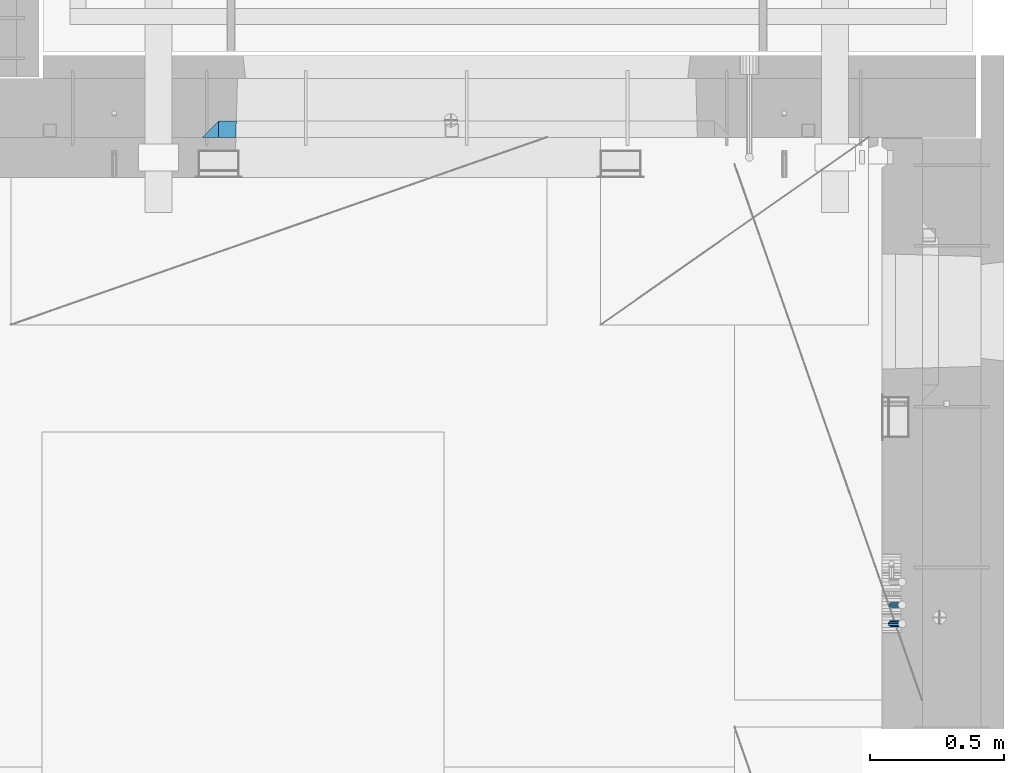
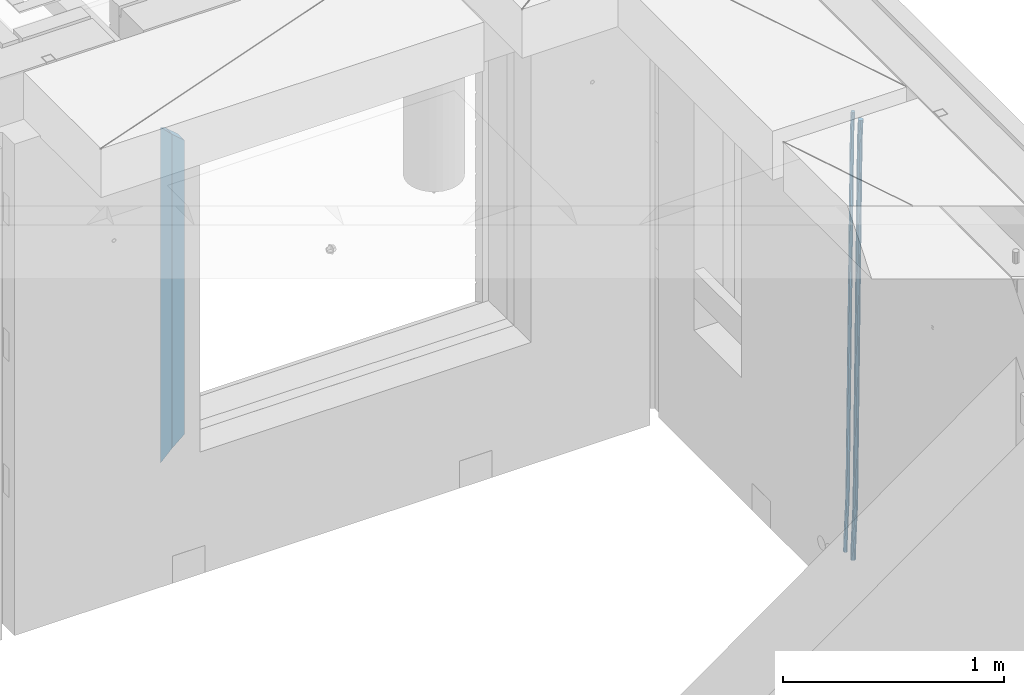
# One storey, part 134 of 349: 4 beams, 2 elements without a shape of their own.
"""IFC2X3 building model written with IfcOpenShell, lengths in millimetres."""

from ifc_helpers import new_model, si_unit, frame, origin_with_axes, place, context, subcontext, project, spatial, faceted_brep, material, type_object, element, aggregate, save


model = new_model("IFC2X3")

# Units and contexts
model_context = context("Model", 3, precision=1e-05, world=origin_with_axes())
body_context = subcontext(model_context, "Body", "Model", "MODEL_VIEW")
ifc_project = project(units=[si_unit("LENGTHUNIT", "METRE", prefix="MILLI"), si_unit("AREAUNIT", "SQUARE_METRE"), si_unit("VOLUMEUNIT", "CUBIC_METRE"), si_unit("MASSUNIT", "GRAM", prefix="KILO"), si_unit("TIMEUNIT", "SECOND"), si_unit("PLANEANGLEUNIT", "RADIAN"), si_unit("SOLIDANGLEUNIT", "STERADIAN"), si_unit("THERMODYNAMICTEMPERATUREUNIT", "DEGREE_CELSIUS"), si_unit("LUMINOUSINTENSITYUNIT", "LUMEN")], contexts=[model_context])

# Site, building, storey
site_placement = place(None, origin_with_axes())
site = spatial("IfcSite", under=ifc_project, at=site_placement, CompositionType="ELEMENT")
building_placement = place(site_placement, origin_with_axes())
building = spatial("IfcBuilding", under=site, at=building_placement, CompositionType="ELEMENT")
storey_placement = place(building_placement, origin_with_axes())
storey = spatial("IfcBuildingStorey", under=building, at=storey_placement, Name="4", CompositionType="ELEMENT", Elevation=0.0)

# Assembly, beams
assembly_1_placement = place(storey_placement, origin_with_axes())
assembly_1 = element("IfcElementAssembly", 1, at=assembly_1_placement, inside=storey, AssemblyPlace="NOTDEFINED", PredefinedType="REINFORCEMENT_UNIT")
ifc_material_1 = material()
beam_type_1 = type_object("IfcBeamType", Name="D20", PredefinedType="NOTDEFINED")
beam_1_placement = place(assembly_1_placement, frame((34944.9999977209, 18835.0002441367, 90990.0), z_axis=(0.999642804629538, 0.000205762999925497, -0.0267249099901003), x_axis=(0.0267249109941254, -4.30000210532798e-08, 0.999642825779465)))
beam_1 = element("IfcBeam", 2, at=beam_1_placement, type_object=beam_type_1, material=ifc_material_1, Name="JM20", ObjectType="D20", context=body_context, shape_type="Brep", body=[
    faceted_brep([(0.0, -10.0, 0.0), (-4.19531716033816e-08, -7.07106781186667, -7.07106781187031), (60.4266690400545, -7.0710677960451, -7.07106780570757), (60.4266690441291, -9.99999998418934, 6.15546014159918e-09), (0.0, 0.0, -10.0), (60.426669036824, 1.58106558956206e-08, -9.99999999384454), (4.196772351861e-08, 7.07106781186303, -7.07106781186667), (60.4266690363438, 7.07106782768096, -7.07106780570757), (0.0, 10.0, 0.0), (60.4266690388904, 10.0000000158179, 6.15182216279209e-09), (4.196772351861e-08, 7.07106781185939, 7.07106781185939), (60.4266690429649, 7.07106782768096, 7.07106781802577), (0.0, 0.0, 10.0), (60.4266690461809, 1.58179318532348e-08, 10.0000000061555), (-4.19531716033816e-08, -7.07106781187031, 7.07106781185939), (60.4266690466611, -7.07106779605238, 7.07106781802213), (61.0378400410118, -7.07106779588503, -7.07106780564936), (60.991799419251, -9.99999998403655, 6.21366780251265e-09), (61.0569027789461, 1.5985278878361e-08, -9.99999999378269), (61.0378209396877, 7.07106782784831, -7.07106780564936), (60.9917724058905, 10.0000000159635, 6.21366780251265e-09), (60.9457317841297, 7.07106782781193, 7.0710678180767), (60.9266690461809, 1.59488990902901e-08, 10.0000000062028), (60.9457508854539, -7.07106779591413, 7.0710678180767), (61.6489592143771, -7.07106614513759, -7.06310863441468), (61.5568818710308, -9.9999984576425, 0.00735959856683621), (61.6870830769039, 1.71821739058942e-06, -9.99179257185824), (61.6489210170112, 7.07106947854481, -7.06310888312146), (61.556827851804, 10.0000015422847, 0.00735924683976918), (61.4647505084577, 7.07106922979438, 7.07782747982128), (61.4266266459163, 1.36643211590126e-06, 10.0065114172685), (61.464788705809, -7.07106639389531, 7.07782772852806), (176.543135720174, -7.07075579406956, -5.56673531796696), (176.451058376813, -9.99968810657447, 1.50373291501455), (176.581259582701, 0.000312069292704109, -8.49541925541052), (176.543097522794, 7.07137982961285, -5.56673556667374), (176.451004357587, 10.00031189336, 1.50373256329476), (176.35892701424, 7.07137958085514, 8.57420079627263), (176.320803151699, 0.000311717507429421, 11.5028847337162), (176.358965211621, -7.07075604281999, 8.57420104497578), (177.098753836006, -7.07075429323595, -5.55949898843028), (176.98362511232, -9.99968666800123, 1.510669025065), (177.146421932586, 0.000313595905026887, -8.48805862247536), (177.098706077581, 7.07138133041735, -5.55949936166144), (176.983557571715, 10.0003133318824, 1.51066849724157), (176.868428848029, 7.07138095712435, 8.58083651073321), (176.820760751449, 0.000313067976094317, 11.5093961447819), (176.868476606425, -7.07075466652896, 8.58083688396073), (177.654312950661, -7.07075204110879, -5.54863964998367), (177.516135294456, -9.99968450931192, 1.52107783331303), (177.711524267797, 0.000315886711177882, -8.47701274570863), (177.654255632195, 7.07138358250813, -5.54864021007961), (177.516054233929, 10.0003154905207, 1.5210770412159), (177.377876577739, 7.0713830223176, 8.59079452451624), (177.320665260588, 0.000315094497636892, 11.5191676202448), (177.377933896176, -7.07075260129932, 8.59079508461218), (299.436796249574, -7.07025836271714, -3.1681962331204), (299.298618593355, -9.99919083092027, 3.90152125031091), (299.494007566798, 0.000809565110102994, -6.09656932889993), (299.436738931283, 7.07187726089978, -3.16819679320906), (299.298537533061, 10.0008091689197, 3.90152045822106), (299.160359876842, 7.07187670072017, 10.9712379416487), (299.103148559603, 0.000808772889286047, 13.8996110374392), (299.160417195119, -7.07025892290039, 10.9712385017483), (299.98743051647, -7.07025613056248, -3.15743315966392), (299.971788958996, -9.99918809853989, 3.91467979818117), (299.993912075952, 0.000811591617093654, -6.08679785393178), (299.987423933868, 7.07187949325817, -3.1574327280432), (299.971753863239, 10.0008119014747, 3.91467990454839), (299.95611230444, 7.07187992653053, 10.9867922621015), (299.949630744944, 0.000812204350950196, 13.9161569563694), (299.956118887014, -7.07025569729012, 10.9867918304735), (300.538107039494, -7.07025785017686, -3.16575821840888), (300.644985195438, -9.99919020432935, 3.90450175465594), (300.493854948218, 0.000810030429420294, -6.09435592770024), (300.538151196495, 7.071877773491, -3.16575855385963), (300.645047642858, 10.0008097955724, 3.90450128024895), (300.751925798773, 7.07187744142357, 10.9747612533101), (300.796177890064, 0.000809560813650023, 13.9033589625978), (300.751881641787, -7.07025818224065, 10.9747615887682), (2293.36490490142, -7.07648090940347, -33.2930642912361), (2293.47178305736, -10.0054132635523, -26.2228043181785), (2293.32065281013, -0.00541302880083094, -36.2216620005347), (2293.36494905842, 7.06565471425711, -33.2930646266868), (2293.47184550477, 9.99458673634581, -26.2228047925819), (2293.57872366071, 7.06565438219332, -19.1525448195243), (2293.62297575199, -0.00541349841296324, -16.2239471102366), (2293.57867950371, -7.0764812414709, -19.1525444840736), (2294.0658245362, -7.07648309818615, -33.3036607065333), (2294.05312277409, -10.0054150789219, -26.2315929392535), (2294.10928714235, -0.00541549149056664, -36.2335844756526), (2294.15805078732, 7.06565223761572, -33.3050546393533), (2294.18355038921, 9.99458451388637, -26.2335642579346), (2294.17084862708, 7.06565253314329, -19.1614964906439), (2294.12738602093, -0.00541507354500936, -16.2315727215355), (2294.07862237596, -7.07648280265857, -19.1601025578348), (2294.76670261032, -7.08562269121467, -33.294332712383), (2294.63442802057, -10.0129954178956, -26.2238563411993), (2294.89787471293, -0.0156988342423574, -36.2230891548279), (2294.95110548967, 7.05531064255774, -33.2944998654275), (2294.89521307347, 9.98530428734011, -26.2240927312887), (2294.76293848372, 7.0579315606592, -19.1536163601049), (2294.63176638114, -0.0119922963167483, -16.2248599176673), (2294.57853560438, -7.08300177311321, -19.1534492070678), (2316.52657204497, -7.36937582653991, -33.0047303660212), (2316.39429745522, -10.2967485532172, -25.9342539948302), (2316.65774414754, -0.299451969567599, -35.9334868084661), (2316.7109749243, 6.7715575072325, -33.0048975190657), (2316.65508250811, 9.70155115201487, -25.9344903849269), (2316.52280791836, 6.7741784253376, -18.8640140137468), (2316.39163581574, -0.295745431634714, -15.9352575713092), (2316.33840503903, -7.36675490843481, -18.863846860706), (2317.16202064224, -7.37766220584308, -32.9962731735213), (2317.05438744847, -10.3053562613532, -25.9254688497131), (2317.23607125619, -0.306993473008333, -35.925789846493), (2317.23316144495, 6.76474808850253, -32.9979477328052), (2317.15499573652, 9.6950321815566, -25.9278370341635), (2317.04736254275, 6.7673381260538, -18.8570327103698), (2316.97331192881, -0.303330606784584, -15.9275160373909), (2316.97622174003, -7.37507216829545, -18.8553581510787), (2317.79752306276, -7.37578610372293, -32.9880110666527), (2317.71453320107, -10.3033876998124, -25.9168792378296), (2317.81444760226, -0.305295583297266, -35.918287695793), (2317.75539265381, 6.76628640723357, -32.9911928173897), (2317.65495180529, 9.69652304524061, -25.9213789128698), (2317.5719619436, 6.76892144914746, -18.8502470840467), (2317.55503740412, -0.301569071270933, -15.9199704549137), (2317.61409235255, -7.3731510618054, -18.847065333317), (2417.8183084176, -7.07752398473531, -31.6906369377139), (2417.73531855589, -10.0051255808248, -24.6195051088798), (2417.83523295709, -0.007033464313281, -34.6209135668432), (2417.77617800863, 7.06454852621755, -31.6938186884508), (2417.67573716014, 9.99478516423187, -24.6240047839383), (2417.59274729842, 7.06718356813872, -17.5528729551006), (2417.57582275895, -0.00330695228694822, -14.6225963259749), (2417.6348777074, -7.07488894281778, -17.5496912043673)], [[[0, 1, 2, 3]], [[1, 4, 5, 2]], [[4, 6, 7, 5]], [[6, 8, 9, 7]], [[8, 10, 11, 9]], [[10, 12, 13, 11]], [[12, 14, 15, 13]], [[14, 0, 3, 15]], [[14, 12, 10, 8, 6, 4, 1, 0]], [[3, 2, 16, 17]], [[2, 5, 18, 16]], [[5, 7, 19, 18]], [[7, 9, 20, 19]], [[9, 11, 21, 20]], [[11, 13, 22, 21]], [[13, 15, 23, 22]], [[15, 3, 17, 23]], [[17, 16, 24, 25]], [[16, 18, 26, 24]], [[18, 19, 27, 26]], [[19, 20, 28, 27]], [[20, 21, 29, 28]], [[21, 22, 30, 29]], [[22, 23, 31, 30]], [[23, 17, 25, 31]], [[25, 24, 32, 33]], [[24, 26, 34, 32]], [[26, 27, 35, 34]], [[27, 28, 36, 35]], [[28, 29, 37, 36]], [[29, 30, 38, 37]], [[30, 31, 39, 38]], [[31, 25, 33, 39]], [[33, 32, 40, 41]], [[32, 34, 42, 40]], [[34, 35, 43, 42]], [[35, 36, 44, 43]], [[36, 37, 45, 44]], [[37, 38, 46, 45]], [[38, 39, 47, 46]], [[39, 33, 41, 47]], [[41, 40, 48, 49]], [[40, 42, 50, 48]], [[42, 43, 51, 50]], [[43, 44, 52, 51]], [[44, 45, 53, 52]], [[45, 46, 54, 53]], [[46, 47, 55, 54]], [[47, 41, 49, 55]], [[49, 48, 56, 57]], [[48, 50, 58, 56]], [[50, 51, 59, 58]], [[51, 52, 60, 59]], [[52, 53, 61, 60]], [[53, 54, 62, 61]], [[54, 55, 63, 62]], [[55, 49, 57, 63]], [[57, 56, 64, 65]], [[56, 58, 66, 64]], [[58, 59, 67, 66]], [[59, 60, 68, 67]], [[60, 61, 69, 68]], [[61, 62, 70, 69]], [[62, 63, 71, 70]], [[63, 57, 65, 71]], [[65, 64, 72, 73]], [[64, 66, 74, 72]], [[66, 67, 75, 74]], [[67, 68, 76, 75]], [[68, 69, 77, 76]], [[69, 70, 78, 77]], [[70, 71, 79, 78]], [[71, 65, 73, 79]], [[73, 72, 80, 81]], [[72, 74, 82, 80]], [[74, 75, 83, 82]], [[75, 76, 84, 83]], [[76, 77, 85, 84]], [[77, 78, 86, 85]], [[78, 79, 87, 86]], [[79, 73, 81, 87]], [[81, 80, 88, 89]], [[80, 82, 90, 88]], [[82, 83, 91, 90]], [[83, 84, 92, 91]], [[84, 85, 93, 92]], [[85, 86, 94, 93]], [[86, 87, 95, 94]], [[87, 81, 89, 95]], [[89, 88, 96, 97]], [[88, 90, 98, 96]], [[90, 91, 99, 98]], [[91, 92, 100, 99]], [[92, 93, 101, 100]], [[93, 94, 102, 101]], [[94, 95, 103, 102]], [[95, 89, 97, 103]], [[97, 96, 104, 105]], [[96, 98, 106, 104]], [[98, 99, 107, 106]], [[99, 100, 108, 107]], [[100, 101, 109, 108]], [[101, 102, 110, 109]], [[102, 103, 111, 110]], [[103, 97, 105, 111]], [[105, 104, 112, 113]], [[104, 106, 114, 112]], [[106, 107, 115, 114]], [[107, 108, 116, 115]], [[108, 109, 117, 116]], [[109, 110, 118, 117]], [[110, 111, 119, 118]], [[111, 105, 113, 119]], [[113, 112, 120, 121]], [[112, 114, 122, 120]], [[114, 115, 123, 122]], [[115, 116, 124, 123]], [[116, 117, 125, 124]], [[117, 118, 126, 125]], [[118, 119, 127, 126]], [[119, 113, 121, 127]], [[121, 120, 128, 129]], [[120, 122, 130, 128]], [[122, 123, 131, 130]], [[123, 124, 132, 131]], [[124, 125, 133, 132]], [[125, 126, 134, 133]], [[126, 127, 135, 134]], [[127, 121, 129, 135]], [[130, 131, 132, 133, 134, 135, 129, 128]]]),
])
beam_type_2 = type_object("IfcBeamType", Name="D25", PredefinedType="NOTDEFINED")
beam_2_placement = place(assembly_1_placement, frame((34944.9999977209, 18765.0002441367, 90990.0), z_axis=(0.999642804629538, 0.000205762999925497, -0.0267249099901003), x_axis=(0.0267249109941254, -4.30000210532798e-08, 0.999642825779465)))
beam_2 = element("IfcBeam", 3, at=beam_2_placement, type_object=beam_type_2, material=ifc_material_1, Name="JM25", ObjectType="D25", context=body_context, shape_type="Brep", body=[
    faceted_brep([(-7.41420080885291e-08, -12.5, -3.63797880709171e-12), (-6.42030499875546e-08, -10.8253175473074, -6.25000000000364), (60.4103898235917, -10.8253175318459, -6.2499999938409), (60.4103898269532, -12.4999999845422, 6.16273609921336e-09), (-3.70782800018787e-08, -6.25000000000364, -10.8253175473074), (60.4103898202884, -6.24999998454587, -10.8253175411446), (-1.45519152283669e-11, -3.63797880709171e-12, -12.5), (60.4103898179019, 1.54577719513327e-08, -12.4999999938373), (3.70637280866504e-08, 6.25, -10.8253175473074), (60.410389817087, 6.25000001545777, -10.825317541141), (6.42030499875546e-08, 10.8253175473001, -6.25000000000364), (60.410389818062, 10.8253175627578, -6.24999999383726), (7.41420080885291e-08, 12.4999999999927, 0.0), (60.4103898205503, 12.5000000154541, 6.16273609921336e-09), (6.42176019027829e-08, 10.8253175473001, 6.24999999999636), (60.4103898238973, 10.8253175627651, 6.2500000061591), (3.70928319171071e-08, 6.24999999999636, 10.8253175473037), (60.4103898272151, 6.25000001546141, 10.8253175534664), (1.45519152283669e-11, -3.63797880709171e-12, 12.4999999999964), (60.4103898296162, 1.54541339725256e-08, 12.5000000061591), (-3.7049176171422e-08, -6.25000000000364, 10.8253175473001), (60.4103898304165, -6.24999998454587, 10.8253175534701), (-6.41884980723262e-08, -10.8253175473074, 6.25), (60.4103898294561, -10.8253175318459, 6.25000000616637), (61.0324985728803, -10.8253175316895, -6.24999999377542), (60.991802792938, -12.4999999843931, 6.22458173893392e-09), (61.0622854283865, -6.24999998437852, -10.8253175410755), (61.0731819955545, 1.5628756955266e-08, -12.4999999937718), (61.0622685480339, 6.25000001562512, -10.8253175410791), (61.032469335245, 10.8253175629216, -6.24999999377178), (60.9917690322181, 12.5000000156033, 6.22458173893392e-09), (60.9510732522613, 10.8253175629034, 6.25000000621731), (60.9212863967696, 6.25000001558874, 10.8253175535247), (60.9103898296162, 1.55814632307738e-08, 12.5000000062137), (60.9213032771368, -6.24999998441126, 10.8253175535174), (60.9511024898966, -10.8253175317113, 6.25000000621731), (61.6545545670233, -10.8253158516927, -6.24189838219536), (61.573166454793, -12.499998414296, 0.00757164385504439), (61.7141257553885, -6.24999822394238, -10.8168280205282), (61.7359179680789, 1.80548886419274e-06, -12.491368569139), (61.7140919992817, 6.25000177601396, -10.8168282403167), (61.6544960997562, 10.8253192428383, -6.2418987628771), (61.5730989426083, 12.5000015856094, 0.0075712042817031), (61.4917108303925, 10.8253190230062, 6.25704123032847), (61.4321396420273, 6.25000139525582, 10.8319708686649), (61.4103474293224, 1.36582457344048e-06, 12.5065114172721), (61.4321733981196, -6.24999860470052, 10.8319710884571), (61.4917692976451, -10.8253160715249, 6.25704161101385), (176.524302641745, -10.8250056210964, -4.74584321979273), (176.442914529529, -12.4996881836996, 1.50362680625403), (176.583873830095, -6.24968799334965, -9.3207728581292), (176.605666042786, 0.000312036081595579, -10.9953134067364), (176.583840074018, 6.25031200660669, -9.32077307791769), (176.524244174492, 10.8256294734347, -4.74584360047811), (176.44284701733, 12.5003118162058, 1.50362636668069), (176.361458905099, 10.8256292535989, 7.75309639272746), (176.301887716749, 6.25031162585219, 12.3280260310676), (176.280095504058, 0.000311596420942806, 14.0025665796711), (176.301921472827, -6.24968837410415, 12.3280262508561), (176.361517372367, -10.8250058409321, 7.75309677341284), (177.085397012124, -10.8250041057399, -4.73853556792164), (176.983633547483, -12.4996867233749, 1.51066909103247), (177.159881729676, -6.24968643771717, -9.31327097355097), (177.187129580227, 0.000313606451527448, -10.987740468332), (177.159839524218, 6.25031356221734, -9.31327130338468), (177.085323910098, 10.8256309887511, -4.73853613920801), (176.983549136537, 12.5003132764905, 1.51066843136869), (176.881785671867, 10.8256306588555, 7.7598730903228), (176.80730095433, 6.25031299082912, 12.3346084959521), (176.780053103794, 0.000312946667690994, 14.0090779907332), (176.807343159802, -6.2496870091054, 12.3346088257895), (176.881858773908, -10.8250044356355, 7.7598736616128), (177.646431799818, -10.8250018318176, -4.72756919822132), (177.524295146417, -12.4996845320202, 1.52123723245313), (177.735828462886, -6.24968410334986, -9.30201312475765), (177.768531371941, 0.00031596292683389, -10.9763759912421), (177.735777808921, 6.25031589654827, -9.30201361973741), (177.646344064575, 10.8256332626152, -4.72757005553649), (177.524193838486, 12.5003154677688, 1.52123624250817), (177.402057185071, 10.8256327675663, 7.77004267317898), (177.312660521988, 6.2503150390985, 12.3444865997226), (177.279957612933, 0.00031497282179771, 14.0188494661961), (177.312711175953, -6.24968496079964, 12.3444870946951), (177.402144920314, -10.8250023268702, 7.77004353049415), (299.377443161706, -10.8245084454466, -2.34813158632096), (299.255306508276, -12.4991911456491, 3.90067484435349), (299.466839824803, -6.24919071697514, -6.92257551286093), (299.499542733873, 0.0008093492979242, -8.59693837933446), (299.466789170867, 6.250809282923, -6.92257600783341), (299.377355426492, 10.8261266489935, -2.34813244364341), (299.255205200388, 12.5008088541435, 3.90067385440125), (299.133068546944, 10.826126153941, 10.1494802850757), (299.043671883861, 6.25080842546959, 14.7239242116229), (299.010968974762, 0.000808359200163977, 16.3982870780892), (299.043722537797, -6.24919157442127, 14.7239247065918), (299.133156282158, -10.8245089404954, 10.1494811423981), (299.98561436501, -10.8245059804758, -2.33624385599614), (299.97179243555, -12.4991882411778, 3.91467976726199), (299.995742293278, -6.24918857328521, -6.91223722345239), (299.999447243041, 0.000811375455668895, -8.58716690387519), (299.995736475976, 6.25081142679483, -6.91223684201032), (299.985604289133, 10.8261291142808, -2.33624319533556), (299.971750386685, 12.5008117588586, 3.91467993563856), (299.957928457196, 10.8261294971744, 10.1656035610831), (299.947800528913, 6.25081208998381, 14.7415969285394), (299.944095579151, 0.00081214124293183, 16.4165266089549), (299.947806346216, -6.24918791008895, 14.7415965471009), (299.957938533058, -10.8245055975785, 10.1656029004225), (300.593832239858, -10.8245078794353, -2.34543881707941), (300.688302931099, -12.4991904788549, 3.90384712594823), (300.524685350189, -6.24919022474205, -6.92023371784308), (300.499390115292, 0.000809814544481924, -8.59472497713432), (300.524724372954, 6.25080977519247, -6.92023401429469), (300.593899829313, 10.8261272150703, -2.34543933054374), (300.688380976673, 12.5008095210287, 3.90384653304136), (300.782851667915, 10.8261269216127, 10.1531324760799), (300.851998557599, 6.25080926691589, 14.7279273768363), (300.877293792495, 0.000809227632998955, 16.4024186361276), (300.851959534804, -6.24919073302226, 14.7279276732806), (300.782784078474, -10.8245081728965, 10.153132989537), (2293.32930409742, -10.8307295605009, -32.4713622331001), (2293.42377478865, -12.5054121599169, -26.2220762900724), (2293.26015720774, -6.2554119058077, -37.0461571338565), (2293.23486197284, -0.00541186651753378, -38.7206483931477), (2293.26019623051, 6.24458809413409, -37.0461574303008), (2293.32937168686, 10.8199055340046, -32.4713627465644), (2293.42385283421, 12.4945878399631, -26.2220768829684), (2293.51832352545, 10.8199052405434, -19.972790939948), (2293.58747041514, 6.24458758585388, -15.3979960391844), (2293.61276565003, -0.00541245343265473, -13.7235047798931), (2293.58743139236, -6.25541241408428, -15.3979957427327), (2293.51825593603, -10.8307298539585, -19.9727904264691), (2294.0420846676, -10.8307317859326, -32.4821379598216), (2294.03681932652, -12.5054140739521, -26.2313442200393), (2294.06778164886, -6.2554144273563, -37.0583666982457), (2294.10702478497, -0.00541458957013674, -38.7338336404937), (2294.14929890928, 6.24458531819619, -37.0595987724118), (2294.18327670435, 10.8199028679592, -32.4842719748667), (2294.1998538474, 12.4945854171456, -26.2338083683717), (2294.19458850632, 10.819903129126, -19.9830146285858), (2294.16889152506, 6.24458577054975, -15.4067858901581), (2294.12964838895, -0.0054140672327776, -13.7313189479173), (2294.08737426462, -6.2554139749991, -15.4055538159919), (2294.05339646956, -10.8307315247621, -19.9808806135297), (2294.75482297382, -10.84002603931, -32.4726521173216), (2294.64982751427, -12.513407826169, -26.2231856868602), (2294.87535820232, -6.26594539088183, -37.0476186524102), (2294.97913588268, -0.0167870967634371, -38.7222267036377), (2295.0383488692, 6.23299192477134, -37.0477663960555), (2295.03713108998, 10.8087684320271, -32.4729080168181), (2294.97580884799, 12.4844668051373, -26.2234811741473), (2294.87081338844, 10.8110850182784, -19.9740147436787), (2294.7502781599, 6.23700436985018, -15.3990482086047), (2294.64650047956, -0.0121539242718427, -13.7244401573698), (2294.58728749304, -6.26193294580662, -15.3989004649666), (2294.58850527227, -10.8377094530588, -19.9737588441894), (2316.44667268227, -11.1228921988077, -32.1839550346631), (2316.34167722271, -12.7962739856739, -25.9344886042054), (2316.56720791078, -6.54881155039038, -36.7589215697517), (2316.67098559113, -0.299653256264719, -38.4335296209792), (2316.73019857766, 5.95012576527006, -36.759069313397), (2316.72898079845, 10.5259022725259, -32.1842109341669), (2316.66765855643, 12.2016006456361, -25.9347840914961), (2316.56266309689, 10.5282188587698, -19.6853176610275), (2316.44212786836, 5.95413821035254, -15.1103511259389), (2316.33835018802, -0.295020083769487, -13.4357430747186), (2316.27913720149, -6.54479910530426, -15.1102033823008), (2316.28035498071, -11.1205756125637, -19.685061761531), (2317.13234804722, -11.1318335458927, -32.1748293731798), (2317.04181141085, -12.8054038787741, -25.9251705100723), (2317.2154741603, -6.5572650749491, -36.7502937866229), (2317.26891617525, -0.307450393454928, -38.4255717558117), (2317.27835434731, 5.94297770185585, -36.7517739018112), (2317.24125972588, 10.5192220504723, -32.1773930078925), (2317.16757178486, 12.1950816748285, -25.9281307404563), (2317.0770351485, 10.5215113419545, -19.6784718773561), (2316.99390903539, 5.94694287101083, -15.1030074639057), (2316.94046702047, -0.302871810494253, -13.4277294947169), (2316.9310288484, -6.55329990579412, -15.1015273487101), (2316.96812346982, -11.1295442544142, -19.6759082426288), (2317.81808136747, -11.1298054502913, -32.1659056455355), (2317.74200467508, -12.803315894289, -25.9160547315114), (2317.86379538118, -6.55536082026447, -36.7418676070083), (2317.8668976831, -0.305700748642266, -38.417815303761), (2317.82655701396, 5.94458339541234, -36.7446799039099), (2317.75358262347, 10.5207330230332, -32.1707766866384), (2317.66752794063, 12.1965725370646, -25.9216793252963), (2317.59145124823, 10.5230620930706, -19.6718284112721), (2317.54573723453, 5.94861746304377, -15.0958664497994), (2317.54263493262, -0.301042608574789, -13.4199187530394), (2317.58297560175, -6.55132675263303, -15.0930541529051), (2317.65594999224, -11.1274763802539, -19.6669573701693), (2417.81884292323, -10.831603083323, -30.8687911350135), (2417.74276623082, -12.505113527317, -24.618940220982), (2417.86455693691, -6.25715845329614, -35.4447530964935), (2417.86765923884, -0.00749838167394046, -37.1207007932499), (2417.82731856969, 6.24278576237703, -35.4475653933878), (2417.75434417921, 10.8189353900088, -30.8736621761236), (2417.66828949639, 12.494774904033, -24.6245648147851), (2417.59221280397, 10.8212644600353, -18.3747139007501), (2417.54649879028, 6.2468198300121, -13.79875193927), (2417.54339648837, -0.00284024161010166, -12.1228042425173), (2417.5837371575, -6.25312438566107, -13.795939642383), (2417.65671154798, -10.8292740132893, -18.3698428596399)], [[[0, 1, 2, 3]], [[1, 4, 5, 2]], [[4, 6, 7, 5]], [[6, 8, 9, 7]], [[8, 10, 11, 9]], [[10, 12, 13, 11]], [[12, 14, 15, 13]], [[14, 16, 17, 15]], [[16, 18, 19, 17]], [[18, 20, 21, 19]], [[20, 22, 23, 21]], [[22, 0, 3, 23]], [[22, 20, 18, 16, 14, 12, 10, 8, 6, 4, 1, 0]], [[3, 2, 24, 25]], [[2, 5, 26, 24]], [[5, 7, 27, 26]], [[7, 9, 28, 27]], [[9, 11, 29, 28]], [[11, 13, 30, 29]], [[13, 15, 31, 30]], [[15, 17, 32, 31]], [[17, 19, 33, 32]], [[19, 21, 34, 33]], [[21, 23, 35, 34]], [[23, 3, 25, 35]], [[25, 24, 36, 37]], [[24, 26, 38, 36]], [[26, 27, 39, 38]], [[27, 28, 40, 39]], [[28, 29, 41, 40]], [[29, 30, 42, 41]], [[30, 31, 43, 42]], [[31, 32, 44, 43]], [[32, 33, 45, 44]], [[33, 34, 46, 45]], [[34, 35, 47, 46]], [[35, 25, 37, 47]], [[37, 36, 48, 49]], [[36, 38, 50, 48]], [[38, 39, 51, 50]], [[39, 40, 52, 51]], [[40, 41, 53, 52]], [[41, 42, 54, 53]], [[42, 43, 55, 54]], [[43, 44, 56, 55]], [[44, 45, 57, 56]], [[45, 46, 58, 57]], [[46, 47, 59, 58]], [[47, 37, 49, 59]], [[49, 48, 60, 61]], [[48, 50, 62, 60]], [[50, 51, 63, 62]], [[51, 52, 64, 63]], [[52, 53, 65, 64]], [[53, 54, 66, 65]], [[54, 55, 67, 66]], [[55, 56, 68, 67]], [[56, 57, 69, 68]], [[57, 58, 70, 69]], [[58, 59, 71, 70]], [[59, 49, 61, 71]], [[61, 60, 72, 73]], [[60, 62, 74, 72]], [[62, 63, 75, 74]], [[63, 64, 76, 75]], [[64, 65, 77, 76]], [[65, 66, 78, 77]], [[66, 67, 79, 78]], [[67, 68, 80, 79]], [[68, 69, 81, 80]], [[69, 70, 82, 81]], [[70, 71, 83, 82]], [[71, 61, 73, 83]], [[73, 72, 84, 85]], [[72, 74, 86, 84]], [[74, 75, 87, 86]], [[75, 76, 88, 87]], [[76, 77, 89, 88]], [[77, 78, 90, 89]], [[78, 79, 91, 90]], [[79, 80, 92, 91]], [[80, 81, 93, 92]], [[81, 82, 94, 93]], [[82, 83, 95, 94]], [[83, 73, 85, 95]], [[85, 84, 96, 97]], [[84, 86, 98, 96]], [[86, 87, 99, 98]], [[87, 88, 100, 99]], [[88, 89, 101, 100]], [[89, 90, 102, 101]], [[90, 91, 103, 102]], [[91, 92, 104, 103]], [[92, 93, 105, 104]], [[93, 94, 106, 105]], [[94, 95, 107, 106]], [[95, 85, 97, 107]], [[97, 96, 108, 109]], [[96, 98, 110, 108]], [[98, 99, 111, 110]], [[99, 100, 112, 111]], [[100, 101, 113, 112]], [[101, 102, 114, 113]], [[102, 103, 115, 114]], [[103, 104, 116, 115]], [[104, 105, 117, 116]], [[105, 106, 118, 117]], [[106, 107, 119, 118]], [[107, 97, 109, 119]], [[109, 108, 120, 121]], [[108, 110, 122, 120]], [[110, 111, 123, 122]], [[111, 112, 124, 123]], [[112, 113, 125, 124]], [[113, 114, 126, 125]], [[114, 115, 127, 126]], [[115, 116, 128, 127]], [[116, 117, 129, 128]], [[117, 118, 130, 129]], [[118, 119, 131, 130]], [[119, 109, 121, 131]], [[121, 120, 132, 133]], [[120, 122, 134, 132]], [[122, 123, 135, 134]], [[123, 124, 136, 135]], [[124, 125, 137, 136]], [[125, 126, 138, 137]], [[126, 127, 139, 138]], [[127, 128, 140, 139]], [[128, 129, 141, 140]], [[129, 130, 142, 141]], [[130, 131, 143, 142]], [[131, 121, 133, 143]], [[133, 132, 144, 145]], [[132, 134, 146, 144]], [[134, 135, 147, 146]], [[135, 136, 148, 147]], [[136, 137, 149, 148]], [[137, 138, 150, 149]], [[138, 139, 151, 150]], [[139, 140, 152, 151]], [[140, 141, 153, 152]], [[141, 142, 154, 153]], [[142, 143, 155, 154]], [[143, 133, 145, 155]], [[145, 144, 156, 157]], [[144, 146, 158, 156]], [[146, 147, 159, 158]], [[147, 148, 160, 159]], [[148, 149, 161, 160]], [[149, 150, 162, 161]], [[150, 151, 163, 162]], [[151, 152, 164, 163]], [[152, 153, 165, 164]], [[153, 154, 166, 165]], [[154, 155, 167, 166]], [[155, 145, 157, 167]], [[157, 156, 168, 169]], [[156, 158, 170, 168]], [[158, 159, 171, 170]], [[159, 160, 172, 171]], [[160, 161, 173, 172]], [[161, 162, 174, 173]], [[162, 163, 175, 174]], [[163, 164, 176, 175]], [[164, 165, 177, 176]], [[165, 166, 178, 177]], [[166, 167, 179, 178]], [[167, 157, 169, 179]], [[169, 168, 180, 181]], [[168, 170, 182, 180]], [[170, 171, 183, 182]], [[171, 172, 184, 183]], [[172, 173, 185, 184]], [[173, 174, 186, 185]], [[174, 175, 187, 186]], [[175, 176, 188, 187]], [[176, 177, 189, 188]], [[177, 178, 190, 189]], [[178, 179, 191, 190]], [[179, 169, 181, 191]], [[181, 180, 192, 193]], [[180, 182, 194, 192]], [[182, 183, 195, 194]], [[183, 184, 196, 195]], [[184, 185, 197, 196]], [[185, 186, 198, 197]], [[186, 187, 199, 198]], [[187, 188, 200, 199]], [[188, 189, 201, 200]], [[189, 190, 202, 201]], [[190, 191, 203, 202]], [[191, 181, 193, 203]], [[194, 195, 196, 197, 198, 199, 200, 201, 202, 203, 193, 192]]]),
])
aggregate(assembly_1, [beam_1, beam_2])

assembly_2_placement = place(storey_placement, origin_with_axes())
assembly_2 = element("IfcElementAssembly", 4, at=assembly_2_placement, inside=storey, AssemblyPlace="NOTDEFINED", PredefinedType="REINFORCEMENT_UNIT")
ifc_material_2 = material(Name="CONCRETE/C25/30")
beam_type_3 = type_object("IfcBeamType", PredefinedType="NOTDEFINED")
beam_3_placement = place(assembly_2_placement, frame((32405.0002457424, 20609.9951872276, 93175.0), z_axis=(1.0, 0.0, 0.0), x_axis=(0.0, 0.0, -1.0)))
beam_3 = element("IfcBeam", 5, at=beam_3_placement, type_object=beam_type_3, material=ifc_material_2, Name="SK", context=body_context, shape_type="Brep", body=[
    faceted_brep([(60.0000000000073, 30.0, 30.0), (0.0, -30.0, -30.0), (60.0000000000073, -30.0, 30.0), (1795.00000000001, 30.0, 30.0), (1855.0, -30.0, -30.0), (1795.00000000001, -30.0, 30.0)], [[[0, 1, 2]], [[3, 4, 1, 0]], [[4, 5, 2, 1]], [[5, 3, 0, 2]], [[5, 4, 3]]]),
])
beam_type_4 = type_object("IfcBeamType", PredefinedType="NOTDEFINED")
beam_4_placement = place(assembly_2_placement, frame((32470.0002457424, 20609.9951872276, 93115.0), z_axis=(1.0, 0.0, 0.0), x_axis=(0.0, 0.0, -1.0)))
beam_4 = element("IfcBeam", 6, at=beam_4_placement, type_object=beam_type_4, material=ifc_material_2, Name="SK", context=body_context, shape_type="Brep", body=[
    faceted_brep([(0.0, -30.0, -35.0), (54.9034748914273, -30.0, 29.0540540540533), (56.2934362811066, 30.0, 30.6756756756768), (0.0, 30.0, -35.0), (1678.70656371891, 30.0, 30.6756756756768), (1735.0, 30.0, -35.0), (1735.0, -30.0, -35.0), (1680.09652510857, -30.0, 29.0540540540533)], [[[0, 1, 2, 3]], [[3, 2, 4, 5]], [[5, 6, 0, 3]], [[1, 0, 6, 7]], [[2, 1, 7, 4]], [[6, 5, 4, 7]]]),
])
aggregate(assembly_2, [beam_3, beam_4])

save(model, "model.ifc")
